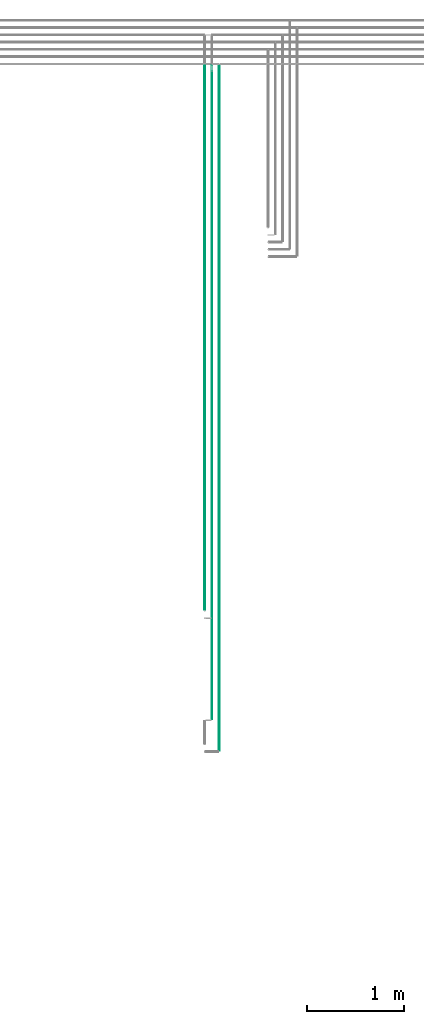
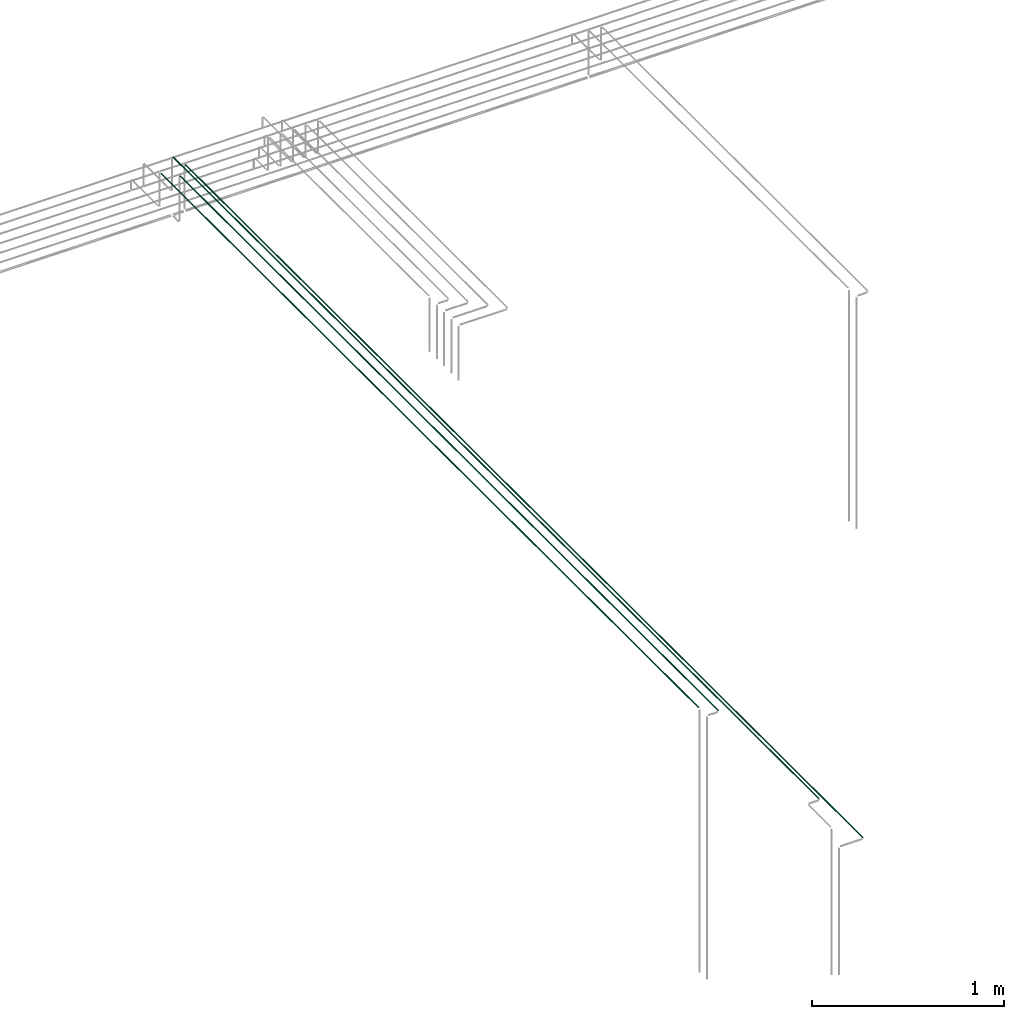
# One storey, part 25 of 89: 4 flow segments.
"""IFC2X3 building model written with IfcOpenShell, lengths in millimetres."""

from ifc_helpers import new_model, entity, si_unit, converted_unit, derived_unit, direction, frame, frame_2d, origin, origin_2d_with_axis, place, context, subcontext, project, spatial, circle, extrude, type_object, element, save


model = new_model("IFC2X3")

# Units and contexts
model_context = context("Model", 3, precision=0.01, world=origin(), true_north=direction((6.12303176911189e-17, 1.0)))
body_context = subcontext(model_context, "Body", "Model", "MODEL_VIEW")
ifc_project = project(units=[si_unit("LENGTHUNIT", "METRE", prefix="MILLI"), si_unit("AREAUNIT", "SQUARE_METRE"), si_unit("VOLUMEUNIT", "CUBIC_METRE"), converted_unit("PLANEANGLEUNIT", "DEGREE", entity("IfcRatioMeasure", 0.0174532925199433), si_unit("PLANEANGLEUNIT", "RADIAN"), dimensions=[0, 0, 0, 0, 0, 0, 0]), si_unit("MASSUNIT", "GRAM", prefix="KILO"), derived_unit("MASSDENSITYUNIT", [(si_unit("MASSUNIT", "GRAM", prefix="KILO"), 1), (si_unit("LENGTHUNIT", "METRE"), -3)]), derived_unit("MOMENTOFINERTIAUNIT", [(si_unit("LENGTHUNIT", "METRE"), 4)]), si_unit("TIMEUNIT", "SECOND"), si_unit("FREQUENCYUNIT", "HERTZ"), si_unit("THERMODYNAMICTEMPERATUREUNIT", "DEGREE_CELSIUS"), derived_unit("THERMALTRANSMITTANCEUNIT", [(si_unit("MASSUNIT", "GRAM", prefix="KILO"), 1), (si_unit("THERMODYNAMICTEMPERATUREUNIT", "KELVIN"), -1), (si_unit("TIMEUNIT", "SECOND"), -3)]), derived_unit("VOLUMETRICFLOWRATEUNIT", [(si_unit("LENGTHUNIT", "METRE"), 3), (si_unit("TIMEUNIT", "SECOND"), -1)]), derived_unit("MASSFLOWRATEUNIT", [(si_unit("MASSUNIT", "GRAM", prefix="KILO"), 1), (si_unit("TIMEUNIT", "SECOND"), -1)]), derived_unit("ROTATIONALFREQUENCYUNIT", [(si_unit("TIMEUNIT", "SECOND"), -1)]), si_unit("ELECTRICCURRENTUNIT", "AMPERE"), si_unit("ELECTRICVOLTAGEUNIT", "VOLT"), si_unit("POWERUNIT", "WATT"), si_unit("FORCEUNIT", "NEWTON", prefix="KILO"), si_unit("ILLUMINANCEUNIT", "LUX"), si_unit("LUMINOUSFLUXUNIT", "LUMEN"), si_unit("LUMINOUSINTENSITYUNIT", "CANDELA"), derived_unit("USERDEFINED", [(si_unit("MASSUNIT", "GRAM", prefix="KILO"), -1), (si_unit("LENGTHUNIT", "METRE"), -2), (si_unit("TIMEUNIT", "SECOND"), 3), (si_unit("LUMINOUSFLUXUNIT", "LUMEN"), 1)]), derived_unit("LINEARVELOCITYUNIT", [(si_unit("LENGTHUNIT", "METRE"), 1), (si_unit("TIMEUNIT", "SECOND"), -1)]), si_unit("PRESSUREUNIT", "PASCAL"), derived_unit("USERDEFINED", [(si_unit("LENGTHUNIT", "METRE"), -2), (si_unit("MASSUNIT", "GRAM", prefix="KILO"), 1), (si_unit("TIMEUNIT", "SECOND"), -2)]), derived_unit("LINEARFORCEUNIT", [(si_unit("MASSUNIT", "GRAM", prefix="KILO"), 1), (si_unit("LENGTHUNIT", "METRE"), 1), (si_unit("TIMEUNIT", "SECOND"), -2), (si_unit("LENGTHUNIT", "METRE"), -1)]), derived_unit("PLANARFORCEUNIT", [(si_unit("MASSUNIT", "GRAM", prefix="KILO"), 1), (si_unit("LENGTHUNIT", "METRE"), 1), (si_unit("TIMEUNIT", "SECOND"), -2), (si_unit("LENGTHUNIT", "METRE"), -2)])], contexts=[model_context])

# Site, building, storey
site_placement = place(None, frame((0.0, -0.00077364408347762, 0.0)))
site = spatial("IfcSite", under=ifc_project, at=site_placement, CompositionType="ELEMENT")
building_placement = place(site_placement, origin())
building = spatial("IfcBuilding", under=site, at=building_placement, CompositionType="ELEMENT")
storey_placement = place(building_placement, frame((0.0, 0.0, 24000.0)))
storey = spatial("IfcBuildingStorey", under=building, at=storey_placement, CompositionType="ELEMENT", Elevation=24000.0)

# Flow segments
pipe_segment_type = type_object("IfcPipeSegmentType", PredefinedType="NOTDEFINED")
flow_segment_1_placement = place(storey_placement, frame((53035.3093686732, 13034.9985534668, 3069.40472776411)))
element("IfcFlowSegment", 1, at=flow_segment_1_placement, inside=storey, type_object=pipe_segment_type, context=body_context, shape_type="SweptSolid", body=[
    extrude(circle(Radius=4.0, at=origin_2d_with_axis()), frame((5.59527223591499, 0.0, 5.59527223591499), z_axis=(0.0, 1.0, 0.0), x_axis=(1.0, 0.0, 0.0)), (0.0, 0.0, 1.0), 5598.15442205637),
])
flow_segment_2_placement = place(storey_placement, frame((53110.3093686732, 12959.9985534668, 3069.4047277641)))
element("IfcFlowSegment", 2, at=flow_segment_2_placement, inside=storey, type_object=pipe_segment_type, context=body_context, shape_type="SweptSolid", body=[
    extrude(circle(Radius=4.0, at=frame_2d((1.73258740687743e-11, 0.0), x_axis=(1.0, 0.0))), frame((5.59527223593232, 0.0, 5.59527223591499), z_axis=(0.0, 1.0, 0.0), x_axis=(-1.0, 0.0, 0.0)), (0.0, 0.0, 1.0), 5605.00144653323),
])
flow_segment_3_placement = place(storey_placement, frame((53110.3093686732, 11909.9985534669, 3144.40472776409)))
element("IfcFlowSegment", 3, at=flow_segment_3_placement, inside=storey, type_object=pipe_segment_type, context=body_context, shape_type="SweptSolid", body=[
    extrude(circle(Radius=4.0, at=origin_2d_with_axis()), frame((5.59527223594964, 0.0, 5.59527223591499), z_axis=(0.0, 1.0, 0.0), x_axis=(1.0, 0.0, 0.0)), (0.0, 0.0, 1.0), 6730.00144653322),
])
flow_segment_4_placement = place(storey_placement, frame((53185.3093686732, 11584.9985534669, 3069.40472776409)))
element("IfcFlowSegment", 4, at=flow_segment_4_placement, inside=storey, type_object=pipe_segment_type, context=body_context, shape_type="SweptSolid", body=[
    extrude(circle(Radius=4.0, at=frame_2d((8.66293703438714e-12, 0.0), x_axis=(1.0, 0.0))), frame((5.59527223593232, 0.0, 5.59527223591499), z_axis=(0.0, 1.0, 0.0), x_axis=(-1.0, 0.0, 0.0)), (0.0, 0.0, 1.0), 7055.00144653319),
])

save(model, "model.ifc")
